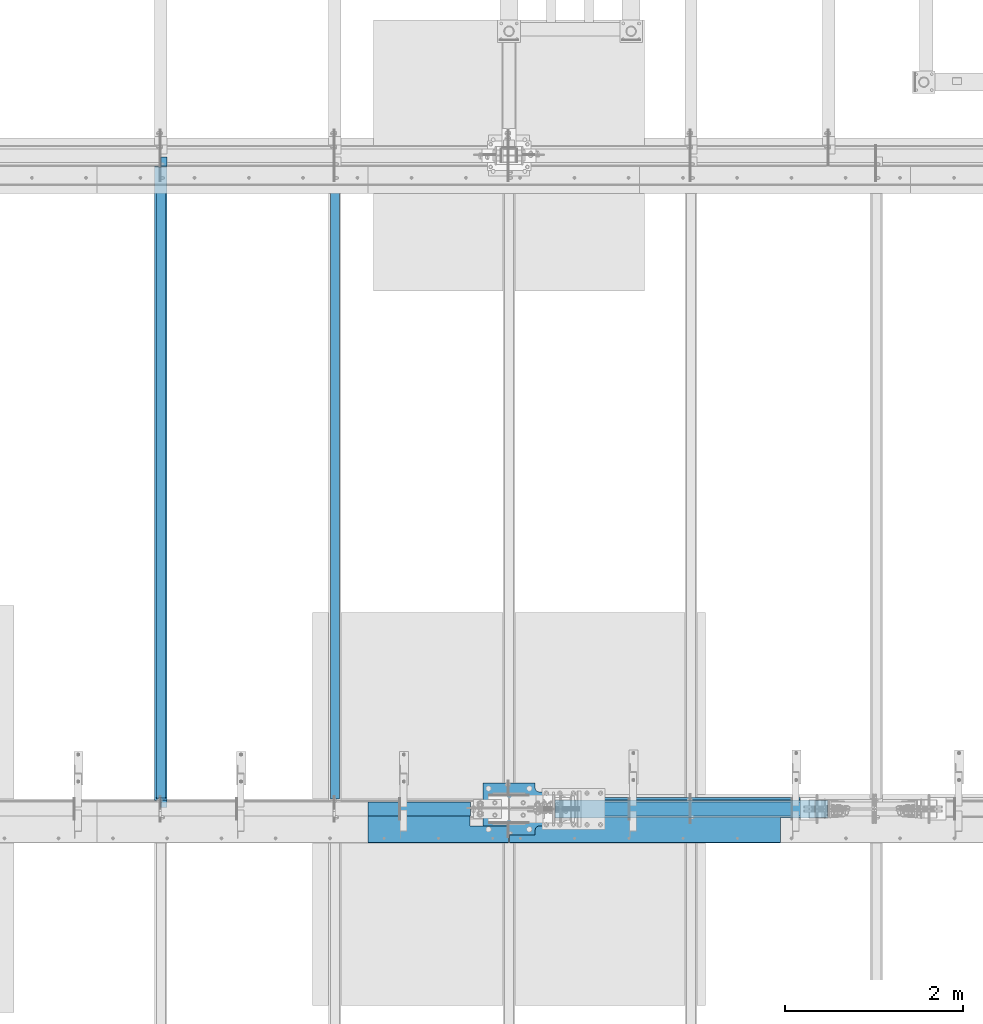
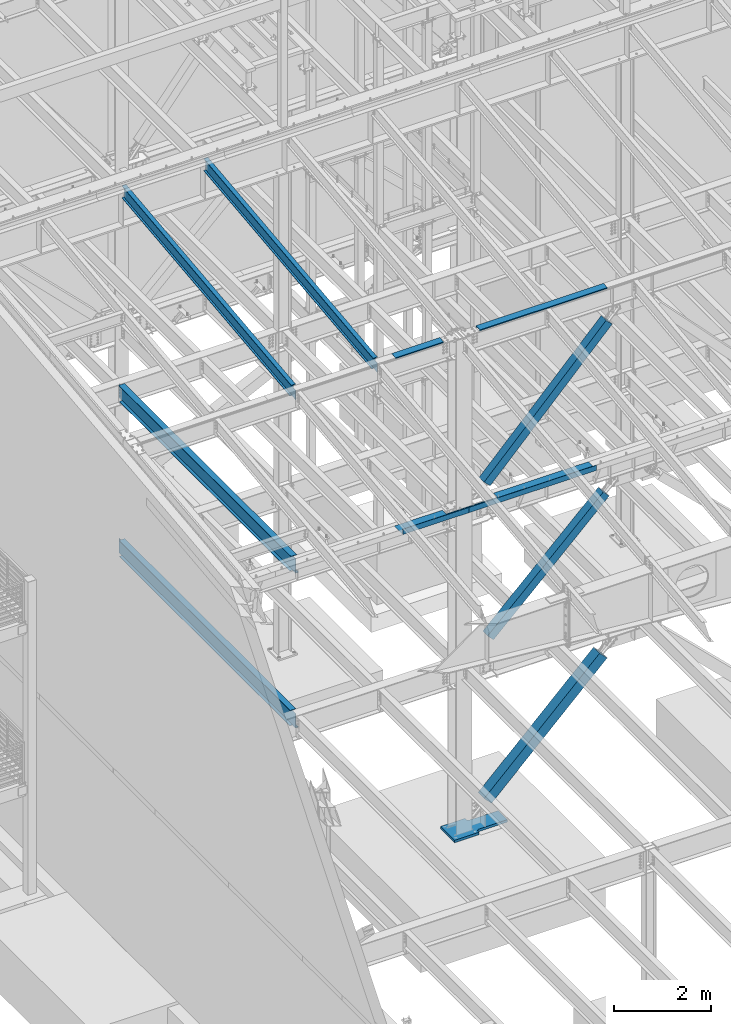
# One storey, part 732 of 1179: 9 beams, 3 members, 12 elements without a shape of their own.
"""IFC2X3 building model written with IfcOpenShell, lengths in millimetres."""

from ifc_helpers import new_model, si_unit, frame, origin_with_axes, place, context, subcontext, project, spatial, faceted_brep, material, type_object, element, aggregate, save


model = new_model("IFC2X3")

# Units and contexts
model_context = context("Model", 3, precision=1e-05, world=origin_with_axes())
body_context = subcontext(model_context, "Body", "Model", "MODEL_VIEW")
ifc_project = project(units=[si_unit("LENGTHUNIT", "METRE", prefix="MILLI"), si_unit("AREAUNIT", "SQUARE_METRE"), si_unit("VOLUMEUNIT", "CUBIC_METRE"), si_unit("MASSUNIT", "GRAM", prefix="KILO"), si_unit("TIMEUNIT", "SECOND"), si_unit("PLANEANGLEUNIT", "RADIAN"), si_unit("SOLIDANGLEUNIT", "STERADIAN"), si_unit("THERMODYNAMICTEMPERATUREUNIT", "DEGREE_CELSIUS"), si_unit("LUMINOUSINTENSITYUNIT", "LUMEN")], contexts=[model_context])

# Site, building, storey
site_placement = place(None, origin_with_axes())
site = spatial("IfcSite", under=ifc_project, at=site_placement, CompositionType="ELEMENT")
building_placement = place(site_placement, origin_with_axes())
building = spatial("IfcBuilding", under=site, at=building_placement, Name="Undefined", CompositionType="ELEMENT")
storey_placement = place(building_placement, origin_with_axes())
storey = spatial("IfcBuildingStorey", under=building, at=storey_placement, Name="Undefined", CompositionType="ELEMENT", Elevation=0.0)

# Assembly, beam
assembly_1_placement = place(storey_placement, origin_with_axes())
assembly_1 = element("IfcElementAssembly", 1, at=assembly_1_placement, inside=storey, Name="BEAM", AssemblyPlace="NOTDEFINED", PredefinedType="RIGID_FRAME")
ifc_material_1 = material(Name="STEEL/A36")
beam_type_1 = type_object("IfcBeamType", PredefinedType="NOTDEFINED")
beam_1_placement = place(assembly_1_placement, frame((10236.2000078262, 27124.025, 12269.3906249899), z_axis=(-1.0, 0.0, 0.0), x_axis=(0.0, 0.0, 1.0)))
beam_1 = element("IfcBeam", 2, at=beam_1_placement, type_object=beam_type_1, material=ifc_material_1, Name="BENT_PLATE", context=body_context, shape_type="Brep", body=[
    faceted_brep([(-2.91038304567337e-11, -4.76250000000073, -1524.0), (-2.91038304567337e-11, -4.76250000000073, 1524.0), (2.91038304567337e-11, 4.76250000000073, 1524.0), (2.91038304567337e-11, 4.76250000000073, -1524.0), (43.0065173285329, 4.76249999974607, 1524.0), (43.0065173285329, 4.76249999974607, -1524.0), (32.344586885798, -4.7625000001899, -1524.0), (32.344586885798, -4.7625000001899, 1524.0), (25.4267482213236, -150.812499999749, 1524.0), (25.4267482213236, -150.812499999749, -1524.0), (16.9174425672263, -141.287499999748, -1524.0), (16.9174425672263, -141.287499999748, 1524.0), (8.54161044117063e-08, -150.812499999749, 1524.0), (8.54161044117063e-08, -150.812499999749, -1524.0), (8.54161044117063e-08, -141.287499999748, 1524.0), (8.54161044117063e-08, -141.287499999748, -1524.0)], [[[0, 1, 2, 3]], [[3, 2, 4, 5]], [[1, 0, 6, 7]], [[5, 4, 8, 9]], [[7, 6, 10, 11]], [[9, 8, 12, 13]], [[8, 4, 2, 1, 7, 11, 14, 12]], [[11, 10, 15, 14]], [[10, 6, 0, 3, 5, 9, 13, 15]], [[14, 15, 13, 12]]]),
])
aggregate(assembly_1, [beam_1])

assembly_2_placement = place(storey_placement, origin_with_axes())
assembly_2 = element("IfcElementAssembly", 3, at=assembly_2_placement, inside=storey, Name="BEAM", AssemblyPlace="NOTDEFINED", PredefinedType="RIGID_FRAME")
beam_2_placement = place(assembly_2_placement, frame((7273.13149999613, 27124.0249999997, 12269.3906250184), z_axis=(-1.0, 0.0, 0.0), x_axis=(0.0, 0.0, 1.0)))
beam_2 = element("IfcBeam", 4, at=beam_2_placement, type_object=beam_type_1, material=ifc_material_1, Name="BENT_PLATE", context=body_context, shape_type="Brep", body=[
    faceted_brep([(-2.91038304567337e-11, -4.76250000000073, -575.469), (-2.91038304567337e-11, -4.76250000000073, 575.469), (2.91038304567337e-11, 4.76250000000073, 575.469), (2.91038304567337e-11, 4.76250000000073, -575.469), (43.0065173000457, 4.76249999974607, 575.469), (43.0065173000457, 4.76249999974607, -575.469), (32.3445868573126, -4.7625000001899, -575.469), (32.3445868573126, -4.7625000001899, 575.469), (25.4267481928364, -150.812499999749, 575.469), (25.4267481928364, -150.812499999749, -575.469), (16.9174425387409, -141.287499999748, -575.469), (16.9174425387409, -141.287499999748, 575.469), (2.84453562926501e-08, -150.812499999749, 575.469), (2.84453562926501e-08, -150.812499999749, -575.469), (2.84453562926501e-08, -141.287499999748, 575.469), (2.84453562926501e-08, -141.287499999748, -575.469)], [[[0, 1, 2, 3]], [[3, 2, 4, 5]], [[1, 0, 6, 7]], [[5, 4, 8, 9]], [[7, 6, 10, 11]], [[9, 8, 12, 13]], [[8, 4, 2, 1, 7, 11, 14, 12]], [[11, 10, 15, 14]], [[10, 6, 0, 3, 5, 9, 13, 15]], [[14, 15, 13, 12]]]),
])
aggregate(assembly_2, [beam_2])

assembly_3_placement = place(storey_placement, origin_with_axes())
assembly_3 = element("IfcElementAssembly", 5, at=assembly_3_placement, inside=storey, Name="BEAM", AssemblyPlace="NOTDEFINED", PredefinedType="RIGID_FRAME")
ifc_material_2 = material(Name="STEEL/A992")
beam_type_2 = type_object("IfcBeamType", Name="W16X31", PredefinedType="NOTDEFINED")
beam_3_placement = place(assembly_3_placement, frame((4368.8, 27051.0, 7812.0875), z_axis=(0.0, 0.0, 1.0), x_axis=(0.0, 1.0, 0.0)))
beam_3 = element("IfcBeam", 6, at=beam_3_placement, type_object=beam_type_2, material=ifc_material_2, Name="BEAM", ObjectType="W16X31", context=body_context, shape_type="Brep", body=[
    faceted_brep([(82.5499999999993, -3.17500000000291, 166.6875), (82.5499999999993, 3.17500000000291, 166.6875), (17.4624999999942, 3.17499999999927, 166.6875), (17.4624999999942, -3.17499999999927, 166.6875), (87.4100797087813, -3.17499999999927, 167.654229922588), (87.4100797087813, 3.17497144083973, 167.654229922588), (91.5302561769349, -3.17499999999927, 170.407243823066), (91.5302561769349, 3.17496966460385, 170.407243823066), (94.2832700774125, -3.17499999999927, 174.52742029122), (94.2832700774125, 3.1749670062818, 174.52742029122), (95.25, -3.17499999999927, 179.387499809265), (95.25, 3.1749638705769, 179.387499809265), (95.25, -69.8499999999985, 201.6125), (95.25, 69.8499999999985, 201.6125), (95.25, 69.8499999999985, 190.5), (95.25, 3.17499999999927, 190.5), (95.25, -3.17499999999927, 190.5), (95.25, -69.8499999999985, 190.5), (7196.1375, 3.17499999999927, -190.5), (7196.1375, 69.8500000000004, -190.5), (144.462499999994, 69.8499999999985, -190.5), (144.462499999994, 3.17549991607666, -190.5), (17.4624999999942, -3.17499999999927, -190.5), (17.4624999999942, -69.8499999999985, -190.5), (7323.1375, -69.8500000000004, -190.5), (7323.1375, -3.17499999999927, -190.5), (17.4624999999942, -69.8499999999985, -201.6125), (7323.1375, -69.8500000000004, -201.6125), (7196.1375, 69.8500000000004, -201.6125), (7196.1375, 3.17549991607484, -201.6125), (7323.1375, 3.17549991607484, -201.6125), (17.4624999999942, 3.17549991607666, -201.6125), (144.462499999994, 3.17549991607666, -201.6125), (144.462499999994, 69.8499999999985, -201.6125), (17.4624999999942, 3.17499999999927, -190.5), (7323.1375, 3.17499999999927, -190.5), (7323.1375, 3.17499999999927, 166.6875), (7323.1375, -3.17499999999927, 166.6875), (7235.82499980928, 3.17499999999927, 166.6875), (7235.82499980928, -3.17499999999927, 166.6875), (7230.96492029123, 3.17499999999927, 167.654229922588), (7230.96492029123, -3.17499999999927, 167.654229922588), (7226.84474382308, 3.17499999999927, 170.407243823066), (7226.84474382308, -3.17499999999927, 170.407243823066), (7224.0917299226, 3.17499999999927, 174.52742029122), (7224.0917299226, -3.17499999999927, 174.52742029122), (7223.12500000001, 3.17499999999927, 179.387499809265), (7223.12500000001, -3.17499999999927, 179.387499809265), (7223.12500000001, -69.8500000000004, 201.6125), (7223.12500000001, -69.8500000000004, 190.5), (7223.12500000001, -3.17499999999927, 190.5), (7223.12500000001, 3.17499999999927, 190.5), (7223.12500000001, 69.8500000000004, 190.5), (7223.12500000001, 69.8500000000004, 201.6125)], [[[0, 1, 2, 3]], [[4, 5, 1, 0]], [[6, 7, 5, 4]], [[8, 9, 7, 6]], [[10, 11, 9, 8]], [[12, 13, 14, 15, 11, 10, 16, 17]], [[18, 19, 20, 21]], [[22, 23, 24, 25]], [[23, 26, 27, 24]], [[28, 29, 30, 27, 26, 31, 32, 33]], [[21, 32, 31, 34]], [[20, 33, 32, 21]], [[19, 28, 33, 20]], [[18, 29, 28, 19]], [[35, 30, 29, 18]], [[25, 24, 27, 30, 35, 36, 37]], [[37, 36, 38, 39]], [[39, 38, 40, 41]], [[41, 40, 42, 43]], [[43, 42, 44, 45]], [[45, 44, 46, 47]], [[48, 49, 50, 47, 46, 51, 52, 53]], [[49, 48, 12, 17]], [[50, 49, 17, 16]], [[8, 6, 4, 0, 3, 22, 25, 37, 39, 41, 43, 45, 47, 50, 16, 10]], [[34, 31, 26, 23, 22, 3, 2]], [[51, 46, 44, 42, 40, 38, 36, 35, 18, 21, 34, 2, 1, 5, 7, 9, 11, 15]], [[52, 51, 15, 14]], [[53, 52, 14, 13]], [[48, 53, 13, 12]]]),
])
aggregate(assembly_3, [beam_3])

assembly_4_placement = place(storey_placement, origin_with_axes())
assembly_4 = element("IfcElementAssembly", 7, at=assembly_4_placement, inside=storey, Name="BEAM", AssemblyPlace="NOTDEFINED", PredefinedType="RIGID_FRAME")
beam_4_placement = place(assembly_4_placement, frame((4368.8, 27051.0, 3900.4875), z_axis=(0.0, 0.0, 1.0), x_axis=(0.0, 1.0, 0.0)))
beam_4 = element("IfcBeam", 8, at=beam_4_placement, type_object=beam_type_2, material=ifc_material_2, Name="BEAM", ObjectType="W16X31", context=body_context, shape_type="Brep", body=[
    faceted_brep([(114.300000190742, -3.17499999999927, 169.8625), (114.300000190742, 3.17497080806788, 169.8625), (19.0500000762049, 3.17499999999382, 169.8625), (19.0499999238054, -3.17500000000564, 169.8625), (119.160079708789, -3.17499999999927, 170.829229922588), (119.160079708789, 3.17497018437643, 170.829229922588), (123.280256176942, -3.17499999999927, 173.582243823066), (123.280256176942, 3.1749684082497, 173.582243823066), (126.03327007742, -3.17499999999927, 177.70242029122), (126.03327007742, 3.17496575008772, 177.70242029122), (127.000000000007, -3.17499999999927, 182.562499809265), (127.000000000007, 3.174962614572, 182.562499809265), (127.000000000007, -69.8499999999985, 201.6125), (127.000000000007, 69.8499999999985, 201.6125), (127.000000000007, 69.8499999999985, 190.5), (127.000000000007, 3.17499999999927, 190.5), (127.000000000007, -3.17499999999927, 190.5), (127.000000000007, -69.8499999999985, 190.5), (7195.34375, 3.17499999999927, -190.5), (7195.34375, 69.8499999999985, -190.5), (146.049999999996, 69.8499999999985, -190.5), (146.049999999996, 3.17549991607666, -190.5), (19.0499999999993, -3.17499999999927, -190.5), (19.0499999999993, -69.8499999999985, -190.5), (7322.34375, -69.8499999999985, -190.5), (7322.34375, -3.17499999999927, -190.5), (19.0499999999993, -69.8499999999985, -201.6125), (7322.34375, -69.8499999999985, -201.6125), (7195.34375, 69.8499999999985, -201.6125), (7195.34375, 3.17561706324705, -201.6125), (7322.34375, 3.17561706324705, -201.6125), (19.0499999999993, 3.17549991607666, -201.6125), (146.049999999996, 3.17549991607666, -201.6125), (146.049999999996, 69.8499999999985, -201.6125), (19.0499999999993, 3.17499999999927, -190.5), (7322.34375, 3.17499999999927, -190.5), (7322.34375, 3.17499999999927, 169.8625), (7322.34375, -3.17499999999927, 169.8625), (7227.09374980925, 3.17499999999927, 169.8625), (7227.09374980925, -3.17499999999927, 169.8625), (7222.2336702912, 3.17499999999927, 170.829229922588), (7222.2336702912, -3.17499999999927, 170.829229922588), (7218.11349382305, 3.17499999999927, 173.582243823066), (7218.11349382305, -3.17499999999927, 173.582243823066), (7215.36047992257, 3.17499999999927, 177.70242029122), (7215.36047992257, -3.17499999999927, 177.70242029122), (7214.39374999998, 3.17499999999927, 182.562499809265), (7214.39374999998, -3.17499999999927, 182.562499809265), (7214.39374999998, -69.8499999999985, 201.6125), (7214.39374999998, -69.8499999999985, 190.5), (7214.39374999998, -3.17499999999927, 190.5), (7214.39374999998, 3.17499999999927, 190.5), (7214.39374999998, 69.8499999999985, 190.5), (7214.39374999998, 69.8499999999985, 201.6125)], [[[0, 1, 2, 3]], [[4, 5, 1, 0]], [[6, 7, 5, 4]], [[8, 9, 7, 6]], [[10, 11, 9, 8]], [[12, 13, 14, 15, 11, 10, 16, 17]], [[18, 19, 20, 21]], [[22, 23, 24, 25]], [[23, 26, 27, 24]], [[28, 29, 30, 27, 26, 31, 32, 33]], [[21, 32, 31, 34]], [[20, 33, 32, 21]], [[19, 28, 33, 20]], [[18, 29, 28, 19]], [[35, 30, 29, 18]], [[25, 24, 27, 30, 35, 36, 37]], [[37, 36, 38, 39]], [[39, 38, 40, 41]], [[41, 40, 42, 43]], [[43, 42, 44, 45]], [[45, 44, 46, 47]], [[48, 49, 50, 47, 46, 51, 52, 53]], [[49, 48, 12, 17]], [[50, 49, 17, 16]], [[8, 6, 4, 0, 3, 22, 25, 37, 39, 41, 43, 45, 47, 50, 16, 10]], [[34, 31, 26, 23, 22, 3, 2]], [[51, 46, 44, 42, 40, 38, 36, 35, 18, 21, 34, 2, 1, 5, 7, 9, 11, 15]], [[52, 51, 15, 14]], [[53, 52, 14, 13]], [[48, 53, 13, 12]]]),
])
aggregate(assembly_4, [beam_4])

# Assembly, member
assembly_5_placement = place(storey_placement, origin_with_axes())
assembly_5 = element("IfcElementAssembly", 9, at=assembly_5_placement, inside=storey, Name="None", AssemblyPlace="NOTDEFINED", PredefinedType="RIGID_FRAME")
member_type_1 = type_object("IfcMemberType", Name="HSS8X8X3/16", PredefinedType="NOTDEFINED")
member_1_placement = place(assembly_5_placement, frame((8872.68862289483, 27051.0, 8361.41390970215), z_axis=(0.0, -1.0, 0.0), x_axis=(0.689394506161203, 0.0, 0.724386095169387)))
member_1 = element("IfcMember", 10, at=member_1_placement, type_object=member_type_1, material=ifc_material_2, Name="None", ObjectType="HSS8X8X3/16", context=body_context, shape_type="Brep", body=[
    faceted_brep([(-3.63797880709171e-12, 96.8374999999978, -96.8375000000015), (-3.63797880709171e-12, -96.8374999999978, -96.8375000000015), (4230.75809404147, -96.8375000024389, -96.8375000000015), (4230.75809404158, 96.8374999976659, -96.8375000000015), (-3.63797880709171e-12, -96.8374999999978, 96.8375000000015), (4230.75809404147, -96.8375000024389, 96.8375000000015), (-3.63797880709171e-12, 96.8374999999978, 96.8375000000015), (4230.75809404158, 96.8374999976659, 96.8375000000015), (-3.63797880709171e-12, 101.599999999999, -101.599999999999), (-3.63797880709171e-12, 101.599999999999, 101.599999999999), (4230.75809404159, 101.59999999767, 101.599999999999), (4230.75809404159, 101.59999999767, -101.599999999999), (0.0, -101.599999999999, 101.599999999999), (4230.75809404147, -101.600000002443, 101.599999999999), (0.0, -101.599999999999, -101.599999999999), (4230.75809404147, -101.600000002443, -101.599999999999)], [[[0, 1, 2, 3]], [[1, 4, 5, 2]], [[4, 6, 7, 5]], [[6, 0, 3, 7]], [[8, 9, 10, 11]], [[9, 12, 13, 10]], [[12, 14, 15, 13]], [[14, 8, 11, 15]], [[13, 15, 11, 10], [5, 7, 3, 2]], [[14, 12, 9, 8], [6, 4, 1, 0]]]),
])
aggregate(assembly_5, [member_1])

assembly_6_placement = place(storey_placement, origin_with_axes())
assembly_6 = element("IfcElementAssembly", 11, at=assembly_6_placement, inside=storey, Name="None", AssemblyPlace="NOTDEFINED", PredefinedType="RIGID_FRAME")
member_2_placement = place(assembly_6_placement, frame((8955.31825659543, 27051.0, 4443.21278207376), z_axis=(0.0, -1.0, 0.0), x_axis=(0.719495300867139, 0.0, 0.694497308871752)))
member_2 = element("IfcMember", 12, at=member_2_placement, type_object=member_type_1, material=ifc_material_2, Name="None", ObjectType="HSS8X8X3/16", context=body_context, shape_type="Brep", body=[
    faceted_brep([(-3.63797880709171e-12, 96.8374999999978, -96.8375000000015), (-3.63797880709171e-12, -96.8374999999978, -96.8375000000015), (3842.17732918352, -96.837500000076, -96.8375000000015), (3842.17732918352, 96.8375000000178, -96.8375000000015), (-3.63797880709171e-12, -96.8374999999978, 96.8375000000015), (3842.17732918352, -96.837500000076, 96.8375000000015), (-3.63797880709171e-12, 96.8374999999978, 96.8375000000015), (3842.17732918352, 96.8375000000178, 96.8375000000015), (-3.63797880709171e-12, 101.599999999999, -101.599999999999), (-3.63797880709171e-12, 101.599999999999, 101.599999999999), (3842.17732918352, 101.600000000024, 101.599999999999), (3842.17732918352, 101.600000000024, -101.599999999999), (0.0, -101.599999999999, 101.599999999999), (3842.17732918352, -101.600000000077, 101.599999999999), (0.0, -101.599999999999, -101.599999999999), (3842.17732918352, -101.600000000077, -101.599999999999)], [[[0, 1, 2, 3]], [[1, 4, 5, 2]], [[4, 6, 7, 5]], [[6, 0, 3, 7]], [[8, 9, 10, 11]], [[9, 12, 13, 10]], [[12, 14, 15, 13]], [[14, 8, 11, 15]], [[13, 15, 11, 10], [5, 7, 3, 2]], [[14, 12, 9, 8], [6, 4, 1, 0]]]),
])
aggregate(assembly_6, [member_2])

# Assembly, beam
assembly_7_placement = place(storey_placement, origin_with_axes())
assembly_7 = element("IfcElementAssembly", 13, at=assembly_7_placement, inside=storey, Name="BEAM", AssemblyPlace="NOTDEFINED", PredefinedType="RIGID_FRAME")
beam_type_3 = type_object("IfcBeamType", PredefinedType="NOTDEFINED")
beam_5_placement = place(assembly_7_placement, frame((9807.575, 26673.175, 8147.05000610352), z_axis=(1.0, 0.0, 0.0), x_axis=(0.0, 0.0, -1.0)))
beam_5 = element("IfcBeam", 14, at=beam_5_placement, type_object=beam_type_3, material=ifc_material_1, Name="BENT_PLATE", context=body_context, shape_type="Brep", body=[
    faceted_brep([(133.350006103517, 188.912500000002, -739.766068352101), (127.000006103516, 188.912500000002, -739.766068352101), (127.000006103516, 346.074999237058, -739.766068352101), (133.350006103517, 346.074999237058, -739.766068352101), (133.350006103517, 188.912500000002, -1524.0), (127.000006103516, 188.912500000002, -1524.0), (0.0, 3.17499999999927, -1524.0), (6.00266503170133e-10, 3.17500000077416, 1524.00000000052), (127.000006103516, 3.17499999999927, 1524.0), (127.000006103516, 3.17499999999927, -1524.0), (0.0, -3.17499999999927, -1524.0), (6.00266503170133e-10, -3.17499999922438, 1524.00000000052), (133.350006103517, -3.17499999999927, -1524.0), (133.350006103517, -3.17499999999927, 1524.0), (133.350006103517, 346.074999237058, 1524.0), (127.000006103516, 346.074999237058, 1524.0)], [[[0, 1, 2, 3]], [[4, 5, 1, 0]], [[6, 7, 8, 9]], [[10, 11, 7, 6]], [[11, 10, 12, 13]], [[8, 7, 11, 13, 14, 15]], [[15, 14, 3, 2]], [[9, 8, 15, 2, 1, 5]], [[12, 10, 6, 9, 5, 4]], [[14, 13, 12, 4, 0, 3]]]),
])
aggregate(assembly_7, [beam_5])

assembly_8_placement = place(storey_placement, origin_with_axes())
assembly_8 = element("IfcElementAssembly", 15, at=assembly_8_placement, inside=storey, Name="BEAM", AssemblyPlace="NOTDEFINED", PredefinedType="RIGID_FRAME")
beam_6_placement = place(assembly_8_placement, frame((7487.44396123733, 26673.175, 8147.05000610352), z_axis=(1.0, 0.0, 0.0), x_axis=(0.0, 0.0, -1.0)))
beam_6 = element("IfcBeam", 16, at=beam_6_placement, type_object=beam_type_3, material=ifc_material_1, Name="BENT_PLATE", context=body_context, shape_type="Brep", body=[
    faceted_brep([(133.350006103517, 346.074999237058, 354.806040288555), (127.000006103516, 346.074999237058, 354.806040288555), (127.000006103516, 188.912499730926, 354.806040340299), (133.350006103517, 188.912499730926, 354.806040340299), (133.350006103517, 188.912498860253, 789.781540340299), (127.000006103516, 188.912498860253, 789.7815), (0.0, -3.17499999999927, -789.7815), (0.0, -3.17499999999927, 789.7815), (0.0, 3.17499999999927, 789.7815), (0.0, 3.17499999999927, -789.7815), (127.000006103516, 3.17499999999927, 789.7815), (127.000006103516, 3.17499999999927, -789.7815), (133.350006103517, -3.17499999999927, -789.7815), (127.000006103516, 346.074999237058, -789.7815), (133.350006103517, 346.074999237058, -789.7815), (133.350006103517, -3.17499999999927, 789.7815)], [[[0, 1, 2, 3]], [[4, 3, 2, 5]], [[6, 7, 8, 9]], [[9, 8, 10, 11]], [[12, 6, 9, 11, 13, 14]], [[7, 6, 12, 15]], [[10, 8, 7, 15, 4, 5]], [[1, 13, 11, 10, 5, 2]], [[14, 13, 1, 0]], [[15, 12, 14, 0, 3, 4]]]),
])
aggregate(assembly_8, [beam_6])

# Assembly, member
assembly_9_placement = place(storey_placement, origin_with_axes())
assembly_9 = element("IfcElementAssembly", 17, at=assembly_9_placement, inside=storey, Name="None", AssemblyPlace="NOTDEFINED", PredefinedType="RIGID_FRAME")
member_type_2 = type_object("IfcMemberType", Name="HSS10X10X1/4", PredefinedType="NOTDEFINED")
member_3_placement = place(assembly_9_placement, frame((8876.50746959597, 27051.0, 368.174244223733), z_axis=(0.0, -1.0, 0.0), x_axis=(0.714279370137245, 0.0, 0.699860687134476)))
member_3 = element("IfcMember", 18, at=member_3_placement, type_object=member_type_2, material=ifc_material_2, Name="None", ObjectType="HSS10X10X1/4", context=body_context, shape_type="Brep", body=[
    faceted_brep([(-6.09361450187862e-11, 120.650000000031, -120.650000000001), (6.00266503170133e-11, -120.650000000031, -120.650000000001), (3864.45514479118, -120.649999998917, -120.650000000001), (3864.45514479113, 120.65000000114, -120.650000000001), (6.00266503170133e-11, -120.650000000031, 120.650000000001), (3864.45514479118, -120.649999998917, 120.650000000001), (-6.09361450187862e-11, 120.650000000031, 120.650000000001), (3864.45514479113, 120.65000000114, 120.650000000001), (-6.3664629124105e-11, 127.000000000032, -127.0), (-6.3664629124105e-11, 127.000000000032, 127.0), (3864.45514479113, 127.000000001141, 127.0), (3864.45514479113, 127.000000001141, -127.0), (6.2755134422332e-11, -127.000000000033, 127.0), (3864.45514479118, -126.99999999892, 127.0), (6.2755134422332e-11, -127.000000000033, -127.0), (3864.45514479118, -126.99999999892, -127.0)], [[[0, 1, 2, 3]], [[1, 4, 5, 2]], [[4, 6, 7, 5]], [[6, 0, 3, 7]], [[8, 9, 10, 11]], [[9, 12, 13, 10]], [[12, 14, 15, 13]], [[14, 8, 11, 15]], [[13, 15, 11, 10], [5, 7, 3, 2]], [[14, 12, 9, 8], [6, 4, 1, 0]]]),
])
aggregate(assembly_9, [member_3])

# Assembly, beam
assembly_10_placement = place(storey_placement, origin_with_axes())
assembly_10 = element("IfcElementAssembly", 19, at=assembly_10_placement, inside=storey, Name="BEAM", AssemblyPlace="NOTDEFINED", PredefinedType="RIGID_FRAME")
beam_type_4 = type_object("IfcBeamType", Name="W12X22", PredefinedType="NOTDEFINED")
beam_7_placement = place(assembly_10_placement, frame((6324.6, 27068.4779321143, 12149.0171463666), z_axis=(0.0, -0.112284087038017, 0.993676146336441), x_axis=(0.0, 0.993676146336441, 0.112284087038017)))
beam_7 = element("IfcBeam", 20, at=beam_7_placement, type_object=beam_type_4, material=ifc_material_2, Name="BEAM", ObjectType="W12X22", context=body_context, shape_type="Brep", body=[
    faceted_brep([(-15.5407998117698, -3.17499999999927, -144.462499999911), (-16.7964975778959, -3.17487472700668, -155.574999999904), (135.603493906594, -3.17489667232439, -155.574999999968), (135.603493906547, -3.17499999999927, -144.462499999972), (135.603487048622, -50.7999999999993, -144.462499999972), (135.603487048618, -50.7999999999993, -155.574999999964), (7139.32426989316, 3.17499999999927, -144.462500002814), (7139.32426989316, 50.7999999999993, -144.462500002814), (135.603501703274, 50.7999999999993, -144.462499999974), (135.603494845222, 3.17489668907729, -144.462500001895), (135.603494845269, 3.17510329651486, -155.574999999966), (-16.7964975778959, 3.17512524196718, -155.574999999904), (-15.5407998117698, 3.17499999999927, -144.462499999911), (135.603501703274, 50.7999999999993, -155.574999999966), (7138.06857212703, 50.7999999999993, -155.575000002807), (7142.71544233383, 3.17499999999927, -114.451772291532), (7168.54976507951, 3.17499999999927, 114.173235457372), (7171.97241181248, 3.17499999999927, 144.462499997011), (7171.97241181248, 50.7999999999993, 144.462499997011), (7173.22810957861, 50.7999999999993, 155.574999997003), (7173.22810957861, -50.7999999999993, 155.574999997003), (7171.97241181248, -50.7999999999993, 144.462499997011), (7171.97241181248, -3.17499999999927, 144.462499997011), (7139.32426989316, -3.17499999999927, -144.462500002814), (7139.32426989316, -50.7999999999993, -144.462500002814), (7138.06857212703, -50.7999999999993, -155.575000002807), (-14.7372101429282, -3.17499999999927, -137.351003558748), (10.2521606948103, -3.17499999999927, 83.7964659398294), (10.2521606948103, 3.17499999999927, 83.7964659398294), (-14.7371967980653, 3.17499999999927, -137.350885461223), (92.2801267643408, -3.17499999999927, 74.5274145334315), (92.2801267643408, 3.17499999999927, 74.5274145334315), (97.2180202374875, -3.17499999999927, 74.9423214058406), (97.2180202374875, 3.17499999999927, 74.9423214058406), (101.621260964999, -3.17499999999927, 77.215295396114), (101.621260964999, 3.17499999999927, 77.215295396114), (104.819495461597, -3.17499999999927, 81.0002968187928), (104.819495461597, 3.17499999999927, 81.0002968187928), (106.325821517235, -3.17499999999927, 85.7210935183975), (106.325821517235, 3.17499999999927, 85.7210935183975), (112.963522565431, 3.17499999999927, 144.462499999876), (112.963522565431, 50.7999999999993, 144.462499999876), (114.219220331557, 50.7999999999993, 155.57499999987), (114.219220331557, -50.7999999999993, 155.57499999987), (112.963522565431, -50.7999999999993, 144.462499999876), (112.963522565431, -3.17499999999927, 144.462499999876)], [[[0, 1, 2, 3]], [[4, 3, 2, 5]], [[6, 7, 8, 9]], [[9, 10, 11, 12]], [[8, 13, 10, 9]], [[7, 14, 13, 8]], [[6, 15, 16, 17, 18, 19, 20, 21, 22, 23, 24, 25, 14, 7]], [[25, 24, 4, 5]], [[1, 11, 10, 13, 14, 25, 5, 2]], [[26, 27, 28, 29, 12, 11, 1, 0]], [[30, 31, 28, 27]], [[32, 33, 31, 30]], [[34, 35, 33, 32]], [[36, 37, 35, 34]], [[38, 39, 37, 36]], [[17, 16, 15, 6, 9, 12, 29, 28, 31, 33, 35, 37, 39, 40]], [[18, 17, 40, 41]], [[19, 18, 41, 42]], [[20, 19, 42, 43]], [[21, 20, 43, 44]], [[22, 21, 44, 45]], [[43, 42, 41, 40, 39, 38, 45, 44]], [[36, 34, 32, 30, 27, 26, 0, 3, 23, 22, 45, 38]], [[24, 23, 3, 4]]]),
])
aggregate(assembly_10, [beam_7])

assembly_11_placement = place(storey_placement, origin_with_axes())
assembly_11 = element("IfcElementAssembly", 21, at=assembly_11_placement, inside=storey, Name="BEAM", AssemblyPlace="NOTDEFINED", PredefinedType="RIGID_FRAME")
beam_8_placement = place(assembly_11_placement, frame((4368.8, 27068.4779321143, 12149.0171463666), z_axis=(0.0, -0.112284087038017, 0.993676146336441), x_axis=(0.0, 0.993676146336441, 0.112284087038017)))
beam_8 = element("IfcBeam", 22, at=beam_8_placement, type_object=beam_type_4, material=ifc_material_2, Name="BEAM", ObjectType="W12X22", context=body_context, shape_type="Brep", body=[
    faceted_brep([(-15.5407998117698, -3.17499999999927, -144.462499999911), (-16.7964975778959, -3.17487472700668, -155.574999999904), (135.603493906594, -3.17489667232439, -155.574999999968), (135.603493906547, -3.17499999999927, -144.462499999972), (135.603487048622, -50.7999999999993, -144.462499999972), (135.603487048618, -50.7999999999993, -155.574999999964), (7139.32426989316, 3.17499999999927, -144.462500002814), (7139.32426989316, 50.7999999999993, -144.462500002814), (135.603501703274, 50.7999999999993, -144.462499999974), (135.603494845222, 3.17489668907729, -144.462500001895), (135.603494845269, 3.17510329651486, -155.574999999966), (-16.7964975778959, 3.17512524196718, -155.574999999904), (-15.5407998117698, 3.17499999999927, -144.462499999911), (135.603501703274, 50.7999999999993, -155.574999999966), (7138.06857212703, 50.7999999999993, -155.575000002807), (7142.71544233383, 3.17499999999927, -114.451772291532), (7168.54976507951, 3.17499999999927, 114.173235457372), (7171.97241181248, 3.17499999999927, 144.462499997011), (7171.97241181248, 50.7999999999993, 144.462499997011), (7173.22810957861, 50.7999999999993, 155.574999997003), (7173.22810957861, -50.7999999999993, 155.574999997003), (7171.97241181248, -50.7999999999993, 144.462499997011), (7171.97241181248, -3.17499999999927, 144.462499997011), (7139.32426989316, -3.17499999999927, -144.462500002814), (7139.32426989316, -50.7999999999993, -144.462500002814), (7138.06857212703, -50.7999999999993, -155.575000002807), (-14.7372101429282, -3.17499999999927, -137.351003558748), (10.2521606948103, -3.17499999999927, 83.7964659398294), (10.2521606948103, 3.17499999999927, 83.7964659398294), (-14.7371967980653, 3.17499999999927, -137.350885461223), (92.2801267643408, -3.17499999999927, 74.5274145334315), (92.2801267643408, 3.17499999999927, 74.5274145334315), (97.2180202374875, -3.17499999999927, 74.9423214058406), (97.2180202374875, 3.17499999999927, 74.9423214058406), (101.621260964999, -3.17499999999927, 77.215295396114), (101.621260964999, 3.17499999999927, 77.215295396114), (104.819495461597, -3.17499999999927, 81.0002968187928), (104.819495461597, 3.17499999999927, 81.0002968187928), (106.325821517235, -3.17499999999927, 85.7210935183975), (106.325821517235, 3.17499999999927, 85.7210935183975), (112.963522565431, 3.17499999999927, 144.462499999876), (112.963522565431, 50.7999999999993, 144.462499999876), (114.219220331557, 50.7999999999993, 155.57499999987), (114.219220331557, -50.7999999999993, 155.57499999987), (112.963522565431, -50.7999999999993, 144.462499999876), (112.963522565431, -3.17499999999927, 144.462499999876)], [[[0, 1, 2, 3]], [[4, 3, 2, 5]], [[6, 7, 8, 9]], [[9, 10, 11, 12]], [[8, 13, 10, 9]], [[7, 14, 13, 8]], [[6, 15, 16, 17, 18, 19, 20, 21, 22, 23, 24, 25, 14, 7]], [[25, 24, 4, 5]], [[1, 11, 10, 13, 14, 25, 5, 2]], [[26, 27, 28, 29, 12, 11, 1, 0]], [[30, 31, 28, 27]], [[32, 33, 31, 30]], [[34, 35, 33, 32]], [[36, 37, 35, 34]], [[38, 39, 37, 36]], [[17, 16, 15, 6, 9, 12, 29, 28, 31, 33, 35, 37, 39, 40]], [[18, 17, 40, 41]], [[19, 18, 41, 42]], [[20, 19, 42, 43]], [[21, 20, 43, 44]], [[22, 21, 44, 45]], [[43, 42, 41, 40, 39, 38, 45, 44]], [[36, 34, 32, 30, 27, 26, 0, 3, 23, 22, 45, 38]], [[24, 23, 3, 4]]]),
])
aggregate(assembly_11, [beam_8])

assembly_12_placement = place(storey_placement, origin_with_axes())
assembly_12 = element("IfcElementAssembly", 23, at=assembly_12_placement, inside=storey, Name="COLUMN", AssemblyPlace="NOTDEFINED", PredefinedType="RIGID_FRAME")
ifc_material_3 = material(Name="STEEL/A572-GR.50")
beam_type_5 = type_object("IfcBeamType", PredefinedType="NOTDEFINED")
beam_9_placement = place(assembly_12_placement, frame((7988.30050354005, 27051.0, -247.65), z_axis=(0.0, 1.0, 0.0), x_axis=(1.0, 0.0, 0.0)))
beam_9 = element("IfcBeam", 24, at=beam_9_placement, type_object=beam_type_5, material=ifc_material_3, context=body_context, shape_type="Brep", body=[
    faceted_brep([(584.199496459958, -31.75, 292.1), (584.199496459958, -31.75, 241.30000076336), (584.199496459958, 31.75, 241.30000076336), (584.199496459958, 31.75, 292.1), (588.066416150308, -31.75, 221.859682691178), (588.066416150308, 31.75, 221.859682691178), (599.078471752222, -31.75, 205.378976818563), (599.078471752222, 31.75, 205.378976818563), (615.559177624837, -31.75, 194.366921216651), (615.559177624837, 31.75, 194.366921216651), (634.999495697019, -31.75, 190.500001526299), (634.999495697019, 31.75, 190.500001526299), (1320.79949645996, -31.75, 190.500001526299), (1320.79949645996, 31.75, 190.500001526299), (0.0, -31.75, -292.1), (0.0, -31.75, 292.1), (0.0, 31.75, 292.1), (0.0, 31.75, -292.1), (584.199496459958, 31.75, -292.1), (584.199496459958, -31.75, -292.1), (584.199496459958, 31.75, -241.30000076336), (584.199496459958, -31.75, -241.30000076336), (588.066416150308, 31.75, -221.859682691178), (588.066416150308, -31.75, -221.859682691178), (599.078471752222, 31.75, -205.378976818563), (599.078471752222, -31.75, -205.378976818563), (615.559177624837, 31.75, -194.366921216651), (615.559177624837, -31.75, -194.366921216651), (634.999495697019, 31.75, -190.500001526299), (634.999495697019, -31.75, -190.500001526299), (1320.79949645996, -31.75, -190.500001526299), (1320.79949645996, 31.75, -190.500001526299)], [[[0, 1, 2, 3]], [[4, 5, 2, 1]], [[6, 7, 5, 4]], [[8, 9, 7, 6]], [[10, 11, 9, 8]], [[12, 13, 11, 10]], [[14, 15, 16, 17]], [[14, 17, 18, 19]], [[19, 18, 20, 21]], [[21, 20, 22, 23]], [[23, 22, 24, 25]], [[25, 24, 26, 27]], [[27, 26, 28, 29]], [[30, 29, 28, 31]], [[8, 6, 4, 1, 0, 15, 14, 19, 21, 23, 25, 27, 29, 30, 12, 10]], [[16, 15, 0, 3]], [[31, 28, 26, 24, 22, 20, 18, 17, 16, 3, 2, 5, 7, 9, 11, 13]], [[30, 31, 13, 12]]]),
])
aggregate(assembly_12, [beam_9])

save(model, "model.ifc")
